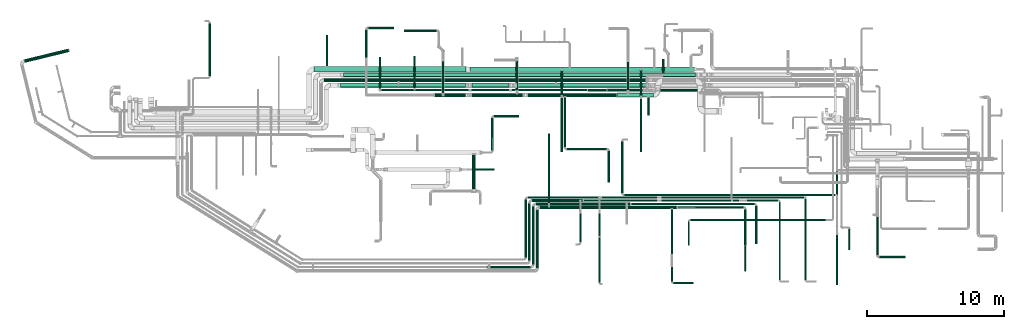
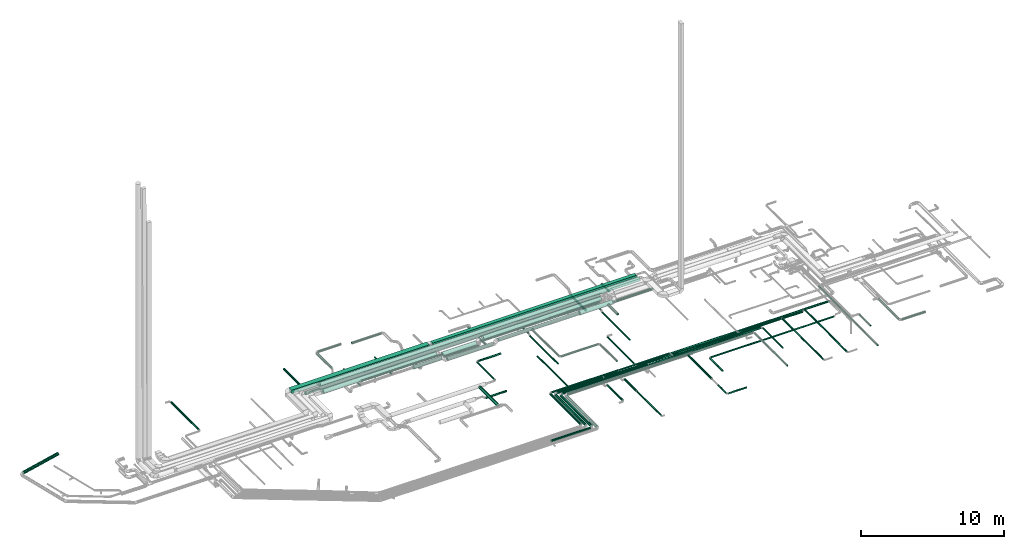
# One storey, part 31 of 92: 77 flow segments.
"""IFC2X3 building model written with IfcOpenShell, lengths in millimetres."""

import ifcopenshell
import ifcopenshell.guid

model = None  # the IFC model being written
_history = None  # IfcOwnerHistory: only IFC2X3 demands one
_inside = {}  # id of a spatial element -> (the spatial element, [elements in it])
_under = {}  # id of a project, library or spatial element -> (it, [spatial elements below it])
_declared = {}  # id of a project -> (the project, [libraries it declares])
_typed = {}  # id of a type object -> (the type object, [elements of that type])
_made_of = {}  # id of a material, layer set ... -> (it, [elements and type objects made of it])


def new_model(schema):
    """Start an empty IFC model of exactly this schema.

    Asked for "IFC4X3", IfcOpenShell would pick the latest addendum, in which some entities
    have other attributes; the version numbers below select the first issue.
    IFC2X3 requires an IfcOwnerHistory on every rooted entity: one is made here for all.
    """
    global model, _history
    if schema == "IFC4X3":
        model = ifcopenshell.file(schema_version=(4, 3, 0, 0))
    else:
        model = ifcopenshell.file(schema=schema)
    _inside.clear()
    _under.clear()
    _declared.clear()
    _typed.clear()
    _made_of.clear()
    _history = None
    if model.schema == "IFC2X3":
        org = make("IfcOrganization", Name="unknown")
        user = make(
            "IfcPersonAndOrganization",
            ThePerson=make("IfcPerson", FamilyName="unknown"),
            TheOrganization=org,
        )
        app = make(
            "IfcApplication",
            ApplicationDeveloper=org,
            Version="unknown",
            ApplicationFullName="unknown",
            ApplicationIdentifier="unknown",
        )
        _history = make(
            "IfcOwnerHistory",
            OwningUser=user,
            OwningApplication=app,
            ChangeAction="ADDED",
            CreationDate=0,
        )
    return model


def make(cls, **values):
    """One entity of the class cls with the attributes given. An attribute that is None is left unset."""
    return model.create_entity(
        cls, **{name: value for name, value in values.items() if value is not None}
    )


def entity(cls, *values):
    """Any entity or typed value of the class cls, its attributes in the order of the schema. None: left unset."""
    e = model.create_entity(cls)
    for i, value in enumerate(values):
        if value is not None:
            e[i] = value
    return e


def rooted(cls, **values):
    """An entity with a GlobalId (a new one), such as an element, a storey or a relation."""
    return make(cls, GlobalId=ifcopenshell.guid.new(), OwnerHistory=_history, **values)


def si_unit(unit_type, name, prefix=None):
    """IfcSIUnit, for example si_unit("LENGTHUNIT", "METRE", prefix="MILLI")."""
    return make("IfcSIUnit", UnitType=unit_type, Prefix=prefix, Name=name)


def converted_unit(unit_type, name, factor, base, dimensions=None, offset=None):
    """IfcConversionBasedUnit, such as the inch: factor (a typed value) times the base unit."""
    return make(
        "IfcConversionBasedUnit"
        if offset is None
        else "IfcConversionBasedUnitWithOffset",
        ConversionOffset=offset,
        Dimensions=None
        if dimensions is None
        else entity("IfcDimensionalExponents", *dimensions),
        UnitType=unit_type,
        Name=name,
        ConversionFactor=make(
            "IfcMeasureWithUnit", ValueComponent=factor, UnitComponent=base
        ),
    )


def derived_unit(unit_type, elements):
    """IfcDerivedUnit: a product of units, each with its exponent."""
    return make(
        "IfcDerivedUnit",
        Elements=[
            make("IfcDerivedUnitElement", Unit=unit, Exponent=power)
            for unit, power in elements
        ],
        UnitType=unit_type,
    )


def assignment(units):
    """IfcUnitAssignment: the units of a project."""
    return None if units is None else make("IfcUnitAssignment", Units=units)


def point(xyz):
    """IfcCartesianPoint."""
    return None if xyz is None else make("IfcCartesianPoint", Coordinates=xyz)


def direction(xyz):
    """IfcDirection."""
    return None if xyz is None else make("IfcDirection", DirectionRatios=xyz)


def frame(location, z_axis=None, x_axis=None):
    """IfcAxis2Placement3D, a coordinate frame: its origin and axes. An axis left out is left unset."""
    return make(
        "IfcAxis2Placement3D",
        Location=point(location),
        Axis=direction(z_axis),
        RefDirection=direction(x_axis),
    )


def frame_2d(location, x_axis=None):
    """IfcAxis2Placement2D, a coordinate frame in the plane: its origin and x axis."""
    return make(
        "IfcAxis2Placement2D", Location=point(location), RefDirection=direction(x_axis)
    )


def origin():
    """The frame at (0, 0, 0) with its axes left unset."""
    return frame((0.0, 0.0, 0.0))


def origin_2d_with_axis():
    """The frame at (0, 0) in the plane with the x axis (1, 0) written out."""
    return frame_2d((0.0, 0.0), x_axis=(1.0, 0.0))


def place(relative_to, where):
    """IfcLocalPlacement: puts the frame where relative to a parent placement (None: the world)."""
    return make(
        "IfcLocalPlacement", PlacementRelTo=relative_to, RelativePlacement=where
    )


def context(
    kind, dimensions, precision=None, world=None, true_north=None, identifier=None
):
    """IfcGeometricRepresentationContext, for example the 3D "Model" context."""
    return make(
        "IfcGeometricRepresentationContext",
        ContextIdentifier=identifier,
        ContextType=kind,
        CoordinateSpaceDimension=dimensions,
        Precision=precision,
        WorldCoordinateSystem=world,
        TrueNorth=true_north,
    )


def subcontext(parent, identifier, kind, view, scale=None):
    """IfcGeometricRepresentationSubContext, for example "Body" below "Model"."""
    return make(
        "IfcGeometricRepresentationSubContext",
        ContextIdentifier=identifier,
        ContextType=kind,
        ParentContext=parent,
        TargetScale=scale,
        TargetView=view,
    )


def project(units=None, contexts=None):
    """IfcProject with its units and contexts."""
    return rooted(
        "IfcProject",
        Name="project",
        RepresentationContexts=contexts,
        UnitsInContext=assignment(units),
    )


def spatial(cls, under=None, at=None, **own):
    """A site, building, storey or space (cls), placed at a placement, below another one or the project."""
    s = rooted(cls, ObjectPlacement=at, **own)
    if under is not None:
        _under.setdefault(under.id(), (under, []))[1].append(s)
    return s


def profile(cls, at=None, kind="AREA", **sizes):
    """A parametric profile (cls). Its sizes go by their IFC names, for example OverallWidth=200.0."""
    return make(cls, ProfileType=kind, Position=at, **sizes)


def rectangle(**sizes):
    """IfcRectangleProfileDef."""
    return profile("IfcRectangleProfileDef", **sizes)


def circle(**sizes):
    """IfcCircleProfileDef."""
    return profile("IfcCircleProfileDef", **sizes)


def extrude(swept, where, along, depth):
    """IfcExtrudedAreaSolid: the profile swept, set in the frame where, extruded along a direction by depth."""
    return make(
        "IfcExtrudedAreaSolid",
        SweptArea=swept,
        Position=where,
        ExtrudedDirection=direction(along),
        Depth=depth,
    )


def shape(context_of_items, identifier, shape_type, items):
    """IfcShapeRepresentation: the items that make up one representation, for example the "Body"."""
    return make(
        "IfcShapeRepresentation",
        ContextOfItems=context_of_items,
        RepresentationIdentifier=identifier,
        RepresentationType=shape_type,
        Items=items,
    )


def made_of(thing, what):
    """Note that an element or type object is made of a material, layer set ...; save() writes the relation."""
    if what is not None:
        _made_of.setdefault(what.id(), (what, []))[1].append(thing)
    return thing


def type_object(cls, material=None, **own):
    """A type object (cls), such as IfcWallType, which elements share."""
    return made_of(rooted(cls, **own), material)


def element(
    cls,
    number,
    at=None,
    inside=None,
    cuts=None,
    type_object=None,
    material=None,
    context=None,
    identifier="Body",
    shape_type=None,
    held_by="IfcProductDefinitionShape",
    body=None,
    shapes=None,
    **own,
):
    """One element of the class cls, such as IfcWall. Its Tag is "e" and its number.

    at: its placement. inside: the storey or other place that contains it. cuts: it is an
    opening in that element (IfcRelVoidsElement). A single representation is given by context,
    identifier, shape_type and body (its items); several are given by shapes. held_by: the class
    of the entity that holds the representations. save() writes the other relations.
    """
    e = rooted(cls, Tag="e%d" % number, ObjectPlacement=at, **own)
    if body is not None:
        shapes = [shape(context, identifier, shape_type, body)]
    if shapes is not None:
        e.Representation = make(held_by, Representations=shapes)
    if inside is not None:
        _inside.setdefault(inside.id(), (inside, []))[1].append(e)
    if cuts is not None:
        rooted(
            "IfcRelVoidsElement", RelatingBuildingElement=cuts, RelatedOpeningElement=e
        )
    if type_object is not None:
        _typed.setdefault(type_object.id(), (type_object, []))[1].append(e)
    return made_of(e, material)


def aggregate(whole, parts):
    """IfcRelAggregates: a whole, such as a stair, and the parts it consists of."""
    return rooted("IfcRelAggregates", RelatingObject=whole, RelatedObjects=parts)


def save(model, path):
    """Write the relations noted so far, then the file.

    IfcRelAggregates (storeys below a building ...), IfcRelContainedInSpatialStructure (elements
    in a storey), IfcRelDefinesByType, IfcRelAssociatesMaterial and IfcRelDeclares: one each for
    every whole, place, type object, material and project.
    """
    for whole, parts in _under.values():
        aggregate(whole, parts)
    for where, things in _inside.values():
        rooted(
            "IfcRelContainedInSpatialStructure",
            RelatedElements=things,
            RelatingStructure=where,
        )
    for kind, things in _typed.values():
        rooted("IfcRelDefinesByType", RelatedObjects=things, RelatingType=kind)
    for what, things in _made_of.values():
        rooted("IfcRelAssociatesMaterial", RelatedObjects=things, RelatingMaterial=what)
    for by, libraries in _declared.values():
        rooted("IfcRelDeclares", RelatingContext=by, RelatedDefinitions=libraries)
    model.write(path)


model = new_model("IFC2X3")

# Units and contexts
model_context = context("Model", 3, precision=0.01, world=origin(), true_north=direction((6.12303176911189e-17, 1.0)))
body_context = subcontext(model_context, "Body", "Model", "MODEL_VIEW")
ifc_project = project(units=[si_unit("LENGTHUNIT", "METRE", prefix="MILLI"), si_unit("AREAUNIT", "SQUARE_METRE"), si_unit("VOLUMEUNIT", "CUBIC_METRE"), converted_unit("PLANEANGLEUNIT", "DEGREE", entity("IfcRatioMeasure", 0.0174532925199433), si_unit("PLANEANGLEUNIT", "RADIAN"), dimensions=[0, 0, 0, 0, 0, 0, 0]), si_unit("MASSUNIT", "GRAM", prefix="KILO"), derived_unit("MASSDENSITYUNIT", [(si_unit("MASSUNIT", "GRAM", prefix="KILO"), 1), (si_unit("LENGTHUNIT", "METRE"), -3)]), derived_unit("MOMENTOFINERTIAUNIT", [(si_unit("LENGTHUNIT", "METRE"), 4)]), si_unit("TIMEUNIT", "SECOND"), si_unit("FREQUENCYUNIT", "HERTZ"), si_unit("THERMODYNAMICTEMPERATUREUNIT", "DEGREE_CELSIUS"), derived_unit("THERMALTRANSMITTANCEUNIT", [(si_unit("MASSUNIT", "GRAM", prefix="KILO"), 1), (si_unit("THERMODYNAMICTEMPERATUREUNIT", "KELVIN"), -1), (si_unit("TIMEUNIT", "SECOND"), -3)]), derived_unit("VOLUMETRICFLOWRATEUNIT", [(si_unit("LENGTHUNIT", "METRE"), 3), (si_unit("TIMEUNIT", "SECOND"), -1)]), derived_unit("MASSFLOWRATEUNIT", [(si_unit("MASSUNIT", "GRAM", prefix="KILO"), 1), (si_unit("TIMEUNIT", "SECOND"), -1)]), derived_unit("ROTATIONALFREQUENCYUNIT", [(si_unit("TIMEUNIT", "SECOND"), -1)]), si_unit("ELECTRICCURRENTUNIT", "AMPERE"), si_unit("ELECTRICVOLTAGEUNIT", "VOLT"), si_unit("POWERUNIT", "WATT"), si_unit("FORCEUNIT", "NEWTON", prefix="KILO"), si_unit("ILLUMINANCEUNIT", "LUX"), si_unit("LUMINOUSFLUXUNIT", "LUMEN"), si_unit("LUMINOUSINTENSITYUNIT", "CANDELA"), derived_unit("USERDEFINED", [(si_unit("MASSUNIT", "GRAM", prefix="KILO"), -1), (si_unit("LENGTHUNIT", "METRE"), -2), (si_unit("TIMEUNIT", "SECOND"), 3), (si_unit("LUMINOUSFLUXUNIT", "LUMEN"), 1)]), derived_unit("LINEARVELOCITYUNIT", [(si_unit("LENGTHUNIT", "METRE"), 1), (si_unit("TIMEUNIT", "SECOND"), -1)]), si_unit("PRESSUREUNIT", "PASCAL"), derived_unit("USERDEFINED", [(si_unit("LENGTHUNIT", "METRE"), -2), (si_unit("MASSUNIT", "GRAM", prefix="KILO"), 1), (si_unit("TIMEUNIT", "SECOND"), -2)]), derived_unit("LINEARFORCEUNIT", [(si_unit("MASSUNIT", "GRAM", prefix="KILO"), 1), (si_unit("LENGTHUNIT", "METRE"), 1), (si_unit("TIMEUNIT", "SECOND"), -2), (si_unit("LENGTHUNIT", "METRE"), -1)]), derived_unit("PLANARFORCEUNIT", [(si_unit("MASSUNIT", "GRAM", prefix="KILO"), 1), (si_unit("LENGTHUNIT", "METRE"), 1), (si_unit("TIMEUNIT", "SECOND"), -2), (si_unit("LENGTHUNIT", "METRE"), -2)])], contexts=[model_context])

# Site, building, storey
site_placement = place(None, origin())
site = spatial("IfcSite", under=ifc_project, at=site_placement, CompositionType="ELEMENT")
building_placement = place(site_placement, origin())
building = spatial("IfcBuilding", under=site, at=building_placement, CompositionType="ELEMENT")
storey_placement = place(building_placement, frame((0.0, 0.0, 4200.0)))
storey = spatial("IfcBuildingStorey", under=building, at=storey_placement, CompositionType="ELEMENT", Elevation=4200.0)

# Flow segments
duct_segment_type_1 = type_object("IfcDuctSegmentType", PredefinedType="NOTDEFINED")
flow_segment_1_placement = place(storey_placement, frame((33469.63, 15979.51, 3150.0)))
element("IfcFlowSegment", 1, at=flow_segment_1_placement, inside=storey, type_object=duct_segment_type_1, context=body_context, shape_type="SweptSolid", body=[
    extrude(rectangle(XDim=16415.04873584, YDim=300.000000000001, at=origin_2d_with_axis()), frame((8208.23, 150.0, 20.0), z_axis=(-0.00243678837898795, 0.0, 0.999997031026791), x_axis=(-0.999997031026791, 0.0, -0.00243678837898795)), (0.0, 0.0, 1.0), 299.999999999999),
])
flow_segment_2_placement = place(storey_placement, frame((22075.0, 15924.51, 3150.0)))
element("IfcFlowSegment", 2, at=flow_segment_2_placement, inside=storey, type_object=duct_segment_type_1, context=body_context, shape_type="SweptSolid", body=[
    extrude(rectangle(XDim=11095.0, YDim=400.0, at=origin_2d_with_axis()), frame((5547.5, 200.0, 0.0), z_axis=(0.0, 0.0, 1.0), x_axis=(-1.0, 0.0, 0.0)), (0.0, 0.0, 1.0), 299.999999999999),
])
duct_segment_type_2 = type_object("IfcDuctSegmentType", PredefinedType="NOTDEFINED")
flow_segment_3_placement = place(storey_placement, frame((63189.76, 2558.91, 3138.4)))
element("IfcFlowSegment", 3, at=flow_segment_3_placement, inside=storey, type_object=duct_segment_type_2, context=body_context, shape_type="SweptSolid", body=[
    extrude(circle(Radius=80.0, at=origin_2d_with_axis()), frame((81.6, 0.0, 81.6), z_axis=(0.0, 1.0, 0.0), x_axis=(1.0, 0.0, 0.0)), (0.0, 0.0, 1.0), 2782.5164097574),
])
flow_segment_4_placement = place(storey_placement, frame((63431.35, 2317.31, 3138.4)))
element("IfcFlowSegment", 4, at=flow_segment_4_placement, inside=storey, type_object=duct_segment_type_2, context=body_context, shape_type="SweptSolid", body=[
    extrude(circle(Radius=80.0, at=origin_2d_with_axis()), frame((0.0, 81.6, 81.6), z_axis=(1.0, 0.0, 0.0), x_axis=(0.0, -1.0, 0.0)), (0.0, 0.0, 1.0), 1889.99999999994),
])
flow_segment_5_placement = place(storey_placement, frame((22935.02, 16344.51, 3218.4)))
element("IfcFlowSegment", 5, at=flow_segment_5_placement, inside=storey, type_object=duct_segment_type_2, context=body_context, shape_type="SweptSolid", body=[
    extrude(circle(Radius=80.0, at=origin_2d_with_axis()), frame((81.6, 0.0, 81.6), z_axis=(0.0, 1.0, 0.0), x_axis=(1.0, 0.0, 0.0)), (0.0, 0.0, 1.0), 2289.99999999988),
])
flow_segment_6_placement = place(storey_placement, frame((14362.46, 15639.71, 2858.4)))
element("IfcFlowSegment", 6, at=flow_segment_6_placement, inside=storey, type_object=duct_segment_type_2, context=body_context, shape_type="SweptSolid", body=[
    extrude(circle(Radius=80.0, at=origin_2d_with_axis()), frame((81.6, 0.0, 81.6), z_axis=(0.0, 1.0, 0.0), x_axis=(1.0, 0.0, 0.0)), (0.0, 0.0, 1.0), 3850.94839972515),
])
flow_segment_7_placement = place(storey_placement, frame((34723.33, 1558.33, 3248.4)))
element("IfcFlowSegment", 7, at=flow_segment_7_placement, inside=storey, type_object=duct_segment_type_2, context=body_context, shape_type="SweptSolid", body=[
    extrude(circle(Radius=100.0, at=origin_2d_with_axis()), frame((0.0, 101.6, 101.6), z_axis=(1.0, 0.0, 0.0), x_axis=(0.0, 1.0, 0.0)), (0.0, 0.0, 1.0), 3176.33865966035),
])
flow_segment_8_placement = place(storey_placement, frame((37998.07, 1859.92, 3248.4)))
element("IfcFlowSegment", 8, at=flow_segment_8_placement, inside=storey, type_object=duct_segment_type_2, context=body_context, shape_type="SweptSolid", body=[
    extrude(circle(Radius=100.0, at=origin_2d_with_axis()), frame((101.6, 0.0, 101.6), z_axis=(0.0, 1.0, 0.0), x_axis=(1.0, 0.0, 0.0)), (0.0, 0.0, 1.0), 4214.89014323062),
])
flow_segment_9_placement = place(storey_placement, frame((38299.67, 6173.22, 3248.4)))
element("IfcFlowSegment", 9, at=flow_segment_9_placement, inside=storey, type_object=duct_segment_type_2, context=body_context, shape_type="SweptSolid", body=[
    extrude(circle(Radius=100.0, at=origin_2d_with_axis()), frame((0.0, 101.6, 101.6), z_axis=(1.0, 0.0, 0.0), x_axis=(0.0, -1.0, 0.0)), (0.0, 0.0, 1.0), 6900.00000000001),
])
flow_segment_10_placement = place(storey_placement, frame((45274.67, 6210.72, 3285.9)))
element("IfcFlowSegment", 10, at=flow_segment_10_placement, inside=storey, type_object=duct_segment_type_2, context=body_context, shape_type="SweptSolid", body=[
    extrude(circle(Radius=62.5, at=origin_2d_with_axis()), frame((0.0, 64.1, 64.1), z_axis=(1.0, 0.0, 0.0), x_axis=(0.0, 1.0, 0.0)), (0.0, 0.0, 1.0), 9009.65781),
])
flow_segment_11_placement = place(storey_placement, frame((54345.23, 3386.61, 3285.9)))
element("IfcFlowSegment", 11, at=flow_segment_11_placement, inside=storey, type_object=duct_segment_type_2, context=body_context, shape_type="SweptSolid", body=[
    extrude(circle(Radius=62.5, at=origin_2d_with_axis()), frame((64.1, 0.0, 64.1), z_axis=(0.0, 1.0, 0.0), x_axis=(-1.0, 0.0, 0.0)), (0.0, 0.0, 1.0), 2763.20000000015),
])
flow_segment_12_placement = place(storey_placement, frame((38288.15, 1579.97, 3248.4)))
element("IfcFlowSegment", 12, at=flow_segment_12_placement, inside=storey, type_object=duct_segment_type_2, context=body_context, shape_type="SweptSolid", body=[
    extrude(circle(Radius=100.0, at=origin_2d_with_axis()), frame((101.6, 0.0, 101.6), z_axis=(0.0, 1.0, 0.0), x_axis=(1.0, 0.0, 0.0)), (0.0, 0.0, 1.0), 4244.85231843357),
])
flow_segment_13_placement = place(storey_placement, frame((38589.74, 5922.98, 3248.4)))
element("IfcFlowSegment", 13, at=flow_segment_13_placement, inside=storey, type_object=duct_segment_type_2, context=body_context, shape_type="SweptSolid", body=[
    extrude(circle(Radius=100.0, at=origin_2d_with_axis()), frame((0.0, 101.6, 101.6), z_axis=(1.0, 0.0, 0.0), x_axis=(0.0, -1.0, 0.0)), (0.0, 0.0, 1.0), 10000.0),
])
flow_segment_14_placement = place(storey_placement, frame((39191.59, 6325.4, 3035.9)))
element("IfcFlowSegment", 14, at=flow_segment_14_placement, inside=storey, type_object=duct_segment_type_2, context=body_context, shape_type="SweptSolid", body=[
    extrude(circle(Radius=62.5, at=origin_2d_with_axis()), frame((64.1, 0.0, 64.1), z_axis=(0.0, 1.0, 0.0), x_axis=(1.0, 0.0, 0.0)), (0.0, 0.0, 1.0), 5076.10296697174),
])
flow_segment_15_placement = place(storey_placement, frame((48664.74, 5960.48, 3285.9)))
element("IfcFlowSegment", 15, at=flow_segment_15_placement, inside=storey, type_object=duct_segment_type_2, context=body_context, shape_type="SweptSolid", body=[
    extrude(circle(Radius=62.5, at=origin_2d_with_axis()), frame((0.0, 64.1, 64.1), z_axis=(1.0, 0.0, 0.0), x_axis=(0.0, 1.0, 0.0)), (0.0, 0.0, 1.0), 4816.79215817312),
])
flow_segment_16_placement = place(storey_placement, frame((53542.44, 3240.11, 3285.9)))
element("IfcFlowSegment", 16, at=flow_segment_16_placement, inside=storey, type_object=duct_segment_type_2, context=body_context, shape_type="SweptSolid", body=[
    extrude(circle(Radius=62.5, at=origin_2d_with_axis()), frame((64.1, 0.0, 64.1), z_axis=(0.0, 1.0, 0.0), x_axis=(-1.0, 0.0, 0.0)), (0.0, 0.0, 1.0), 2659.465339106),
])
flow_segment_17_placement = place(storey_placement, frame((53554.91, 1369.83, 3298.4)))
element("IfcFlowSegment", 17, at=flow_segment_17_placement, inside=storey, type_object=duct_segment_type_2, context=body_context, shape_type="SweptSolid", body=[
    extrude(circle(Radius=50.0, at=origin_2d_with_axis()), frame((51.6, 0.0, 51.6), z_axis=(1.46979839557757e-05, 1.0, 0.0), x_axis=(-1.0, 1.46979839557757e-05, 0.0)), (0.0, 0.0, 1.0), 1845.2883705389),
])
flow_segment_18_placement = place(storey_placement, frame((48158.4, 2604.83, 3268.4)))
element("IfcFlowSegment", 18, at=flow_segment_18_placement, inside=storey, type_object=duct_segment_type_2, context=body_context, shape_type="SweptSolid", body=[
    extrude(circle(Radius=80.0, at=origin_2d_with_axis()), frame((81.6, 0.0, 81.6), z_axis=(0.0, 1.0, 0.0), x_axis=(1.0, 0.0, 0.0)), (0.0, 0.0, 1.0), 3299.75370936451),
])
flow_segment_19_placement = place(storey_placement, frame((48188.4, 595.45, 3298.4)))
element("IfcFlowSegment", 19, at=flow_segment_19_placement, inside=storey, type_object=duct_segment_type_2, context=body_context, shape_type="SweptSolid", body=[
    extrude(circle(Radius=50.0, at=origin_2d_with_axis()), frame((51.6, 0.0, 51.6), z_axis=(0.0, 1.0, 0.0), x_axis=(-1.0, 0.0, 0.0)), (0.0, 0.0, 1.0), 1104.37492000003),
])
flow_segment_20_placement = place(storey_placement, frame((48340.0, 443.86, 3298.4)))
element("IfcFlowSegment", 20, at=flow_segment_20_placement, inside=storey, type_object=duct_segment_type_2, context=body_context, shape_type="SweptSolid", body=[
    extrude(circle(Radius=50.0, at=origin_2d_with_axis()), frame((0.0, 51.6, 51.6), z_axis=(1.0, 0.0, 0.0), x_axis=(0.0, -1.0, 0.0)), (0.0, 0.0, 1.0), 1480.00000000001),
])
flow_segment_21_placement = place(storey_placement, frame((37473.28, 2380.0, 3278.4)))
element("IfcFlowSegment", 21, at=flow_segment_21_placement, inside=storey, type_object=duct_segment_type_2, context=body_context, shape_type="SweptSolid", body=[
    extrude(circle(Radius=80.0, at=origin_2d_with_axis()), frame((81.6, 0.0, 81.6), z_axis=(0.0, 1.0, 0.0), x_axis=(1.0, 0.0, 0.0)), (0.0, 0.0, 1.0), 4215.03973085738),
])
flow_segment_22_placement = place(storey_placement, frame((37714.87, 6673.44, 3278.4)))
element("IfcFlowSegment", 22, at=flow_segment_22_placement, inside=storey, type_object=duct_segment_type_2, context=body_context, shape_type="SweptSolid", body=[
    extrude(circle(Radius=80.0, at=origin_2d_with_axis()), frame((0.0, 81.6, 81.6), z_axis=(1.0, 0.0, 0.0), x_axis=(0.0, 1.0, 0.0)), (0.0, 0.0, 1.0), 5352.89450896011),
])
flow_segment_23_placement = place(storey_placement, frame((42902.64, 523.14, 3298.4)))
element("IfcFlowSegment", 23, at=flow_segment_23_placement, inside=storey, type_object=duct_segment_type_2, context=body_context, shape_type="SweptSolid", body=[
    extrude(circle(Radius=50.0, at=origin_2d_with_axis()), frame((51.6, 0.0, 51.6), z_axis=(0.0, 1.0, 0.0), x_axis=(-1.0, 0.0, 0.0)), (0.0, 0.0, 1.0), 3326.89716131193),
])
flow_segment_24_placement = place(storey_placement, frame((43127.77, 6703.44, 3308.4)))
element("IfcFlowSegment", 24, at=flow_segment_24_placement, inside=storey, type_object=duct_segment_type_2, context=body_context, shape_type="SweptSolid", body=[
    extrude(circle(Radius=50.0, at=origin_2d_with_axis()), frame((0.0, 51.6, 51.6), z_axis=(1.0, 0.0, 0.0), x_axis=(0.0, -1.0, 0.0)), (0.0, 0.0, 1.0), 4060.95188480217),
])
flow_segment_25_placement = place(storey_placement, frame((36908.04, 14797.9, 3140.9)))
element("IfcFlowSegment", 25, at=flow_segment_25_placement, inside=storey, type_object=duct_segment_type_2, context=body_context, shape_type="SweptSolid", body=[
    extrude(circle(Radius=157.5, at=origin_2d_with_axis()), frame((0.0, 159.1, 159.1), z_axis=(1.0, 0.0, 0.0), x_axis=(0.0, 1.0, 0.0)), (0.0, 0.0, 1.0), 9507.22972697121),
])
flow_segment_26_placement = place(storey_placement, frame((871.65, 16601.37, 3233.4)))
element("IfcFlowSegment", 26, at=flow_segment_26_placement, inside=storey, type_object=duct_segment_type_2, context=body_context, shape_type="SweptSolid", body=[
    extrude(circle(Radius=125.0, at=origin_2d_with_axis()), frame((31.2, 123.04, 126.6), z_axis=(0.971552058141474, 0.236826092990333, 0.0), x_axis=(0.236826092990333, -0.971552058141474, 0.0)), (0.0, 0.0, 1.0), 3341.53518929974),
])
flow_segment_27_placement = place(storey_placement, frame((37717.54, 2139.96, 3258.4)))
element("IfcFlowSegment", 27, at=flow_segment_27_placement, inside=storey, type_object=duct_segment_type_2, context=body_context, shape_type="SweptSolid", body=[
    extrude(circle(Radius=100.0, at=origin_2d_with_axis()), frame((101.6, 0.0, 101.6), z_axis=(0.0, 1.0, 0.0), x_axis=(1.0, 0.0, 0.0)), (0.0, 0.0, 1.0), 4184.88732607687),
])
flow_segment_28_placement = place(storey_placement, frame((61159.38, 2924.89, 3098.4)))
element("IfcFlowSegment", 28, at=flow_segment_28_placement, inside=storey, type_object=duct_segment_type_2, context=body_context, shape_type="SweptSolid", body=[
    extrude(circle(Radius=50.0, at=origin_2d_with_axis()), frame((51.6, 0.0, 51.6), z_axis=(0.0, 1.0, 0.0), x_axis=(-1.0, 0.0, 0.0)), (0.0, 0.0, 1.0), 1530.59800714042),
])
flow_segment_29_placement = place(storey_placement, frame((57973.96, 702.32, 3348.4)))
element("IfcFlowSegment", 29, at=flow_segment_29_placement, inside=storey, type_object=duct_segment_type_2, context=body_context, shape_type="SweptSolid", body=[
    extrude(circle(Radius=50.0, at=origin_2d_with_axis()), frame((51.6, 0.0, 51.6), z_axis=(0.0, 1.0, 0.0), x_axis=(-1.0, 0.0, 0.0)), (0.0, 0.0, 1.0), 5952.7187231084),
])
flow_segment_30_placement = place(storey_placement, frame((41469.24, 3479.77, 3263.64)))
element("IfcFlowSegment", 30, at=flow_segment_30_placement, inside=storey, type_object=duct_segment_type_2, context=body_context, shape_type="SweptSolid", body=[
    extrude(circle(Radius=80.0, at=origin_2d_with_axis()), frame((81.6, 0.0, 81.6), z_axis=(0.0, 1.0, 0.0), x_axis=(1.0, 0.0, 0.0)), (0.0, 0.0, 1.0), 2090.73393103333),
])
flow_segment_31_placement = place(storey_placement, frame((52700.11, 6470.75, 3348.4)))
element("IfcFlowSegment", 31, at=flow_segment_31_placement, inside=storey, type_object=duct_segment_type_2, context=body_context, shape_type="SweptSolid", body=[
    extrude(circle(Radius=50.0, at=origin_2d_with_axis()), frame((0.0, 51.6, 51.6), z_axis=(1.0, 0.0, 0.0), x_axis=(0.0, 1.0, 0.0)), (0.0, 0.0, 1.0), 3333.45568879652),
])
flow_segment_32_placement = place(storey_placement, frame((38019.13, 6423.25, 3258.4)))
element("IfcFlowSegment", 32, at=flow_segment_32_placement, inside=storey, type_object=duct_segment_type_2, context=body_context, shape_type="SweptSolid", body=[
    extrude(circle(Radius=100.0, at=origin_2d_with_axis()), frame((0.0, 101.6, 101.6), z_axis=(1.0, 0.0, 0.0), x_axis=(0.0, -1.0, 0.0)), (0.0, 0.0, 1.0), 3694.23043778437),
])
flow_segment_33_placement = place(storey_placement, frame((44554.67, 7068.28, 3095.9)))
element("IfcFlowSegment", 33, at=flow_segment_33_placement, inside=storey, type_object=duct_segment_type_2, context=body_context, shape_type="SweptSolid", body=[
    extrude(circle(Radius=62.5, at=origin_2d_with_axis()), frame((64.1, 0.0, 64.1), z_axis=(0.0, 1.0, 0.0), x_axis=(1.0, 0.0, 0.0)), (0.0, 0.0, 1.0), 3796.71503982172),
])
flow_segment_34_placement = place(storey_placement, frame((44743.77, 6879.19, 3095.9)))
element("IfcFlowSegment", 34, at=flow_segment_34_placement, inside=storey, type_object=duct_segment_type_2, context=body_context, shape_type="SweptSolid", body=[
    extrude(circle(Radius=62.5, at=origin_2d_with_axis()), frame((0.0, 64.1, 64.1), z_axis=(1.0, 0.0, 0.0), x_axis=(0.0, -1.0, 0.0)), (0.0, 0.0, 1.0), 15453.941984164),
])
flow_segment_35_placement = place(storey_placement, frame((56081.97, 700.4, 3348.4)))
element("IfcFlowSegment", 35, at=flow_segment_35_placement, inside=storey, type_object=duct_segment_type_2, context=body_context, shape_type="SweptSolid", body=[
    extrude(circle(Radius=50.0, at=origin_2d_with_axis()), frame((51.6, 0.0, 51.6), z_axis=(0.0, 1.0, 0.0), x_axis=(-1.0, 0.0, 0.0)), (0.0, 0.0, 1.0), 5721.94436317677),
])
flow_segment_36_placement = place(storey_placement, frame((47528.4, 15821.98, 2918.4)))
element("IfcFlowSegment", 36, at=flow_segment_36_placement, inside=storey, type_object=duct_segment_type_2, context=body_context, shape_type="SweptSolid", body=[
    extrude(circle(Radius=80.0, at=origin_2d_with_axis()), frame((81.6, 0.0, 81.6), z_axis=(0.0, 1.0, 0.0), x_axis=(1.0, 0.0, 0.0)), (0.0, 0.0, 1.0), 1069.53796275342),
])
flow_segment_37_placement = place(storey_placement, frame((37727.45, 14115.4, 3173.4)))
element("IfcFlowSegment", 37, at=flow_segment_37_placement, inside=storey, type_object=duct_segment_type_2, context=body_context, shape_type="SweptSolid", body=[
    extrude(circle(Radius=125.0, at=origin_2d_with_axis()), frame((0.0, 126.6, 126.6), z_axis=(1.0, 0.0, 0.0), x_axis=(0.0, 1.0, 0.0)), (0.0, 0.0, 1.0), 6470.60249485662),
])
flow_segment_38_placement = place(storey_placement, frame((40354.43, 10417.36, 3235.9)))
element("IfcFlowSegment", 38, at=flow_segment_38_placement, inside=storey, type_object=duct_segment_type_2, context=body_context, shape_type="SweptSolid", body=[
    extrude(circle(Radius=62.5, at=origin_2d_with_axis()), frame((64.1, 0.0, 64.1), z_axis=(0.0, 1.0, 0.0), x_axis=(1.0, 0.0, 0.0)), (0.0, 0.0, 1.0), 3679.63829635603),
])
flow_segment_39_placement = place(storey_placement, frame((40543.53, 10228.27, 3235.9)))
element("IfcFlowSegment", 39, at=flow_segment_39_placement, inside=storey, type_object=duct_segment_type_2, context=body_context, shape_type="SweptSolid", body=[
    extrude(circle(Radius=62.5, at=origin_2d_with_axis()), frame((0.0, 64.1, 64.1), z_axis=(1.0, 0.0, 0.0), x_axis=(0.0, -1.0, 0.0)), (0.0, 0.0, 1.0), 2950.00000000008),
])
flow_segment_40_placement = place(storey_placement, frame((43554.43, 7853.98, 3235.9)))
element("IfcFlowSegment", 40, at=flow_segment_40_placement, inside=storey, type_object=duct_segment_type_2, context=body_context, shape_type="SweptSolid", body=[
    extrude(circle(Radius=62.5, at=origin_2d_with_axis()), frame((64.1, 0.0, 64.1), z_axis=(0.0, 1.0, 0.0), x_axis=(-1.0, 0.0, 0.0)), (0.0, 0.0, 1.0), 2313.38222094977),
])
flow_segment_41_placement = place(storey_placement, frame((31433.4, 14402.0, 2908.4)))
element("IfcFlowSegment", 41, at=flow_segment_41_placement, inside=storey, type_object=duct_segment_type_2, context=body_context, shape_type="SweptSolid", body=[
    extrude(circle(Radius=80.0, at=origin_2d_with_axis()), frame((81.6, 0.0, 81.6), z_axis=(0.0, 1.0, 0.0), x_axis=(-1.0, 0.0, 0.0)), (0.0, 0.0, 1.0), 2308.20336366427),
])
flow_segment_42_placement = place(storey_placement, frame((28660.55, 18866.88, 3258.4)))
element("IfcFlowSegment", 42, at=flow_segment_42_placement, inside=storey, type_object=duct_segment_type_2, context=body_context, shape_type="SweptSolid", body=[
    extrude(circle(Radius=80.0, at=origin_2d_with_axis()), frame((0.0, 81.6, 81.6), z_axis=(1.0, 0.0, 0.0), x_axis=(0.0, 1.0, 0.0)), (0.0, 0.0, 1.0), 2369.44948828407),
])
flow_segment_43_placement = place(storey_placement, frame((26051.62, 19063.38, 3318.4)))
element("IfcFlowSegment", 43, at=flow_segment_43_placement, inside=storey, type_object=duct_segment_type_2, context=body_context, shape_type="SweptSolid", body=[
    extrude(circle(Radius=80.0, at=origin_2d_with_axis()), frame((0.0, 81.6, 81.6), z_axis=(1.0, 0.0, 0.0), x_axis=(0.0, -1.0, 0.0)), (0.0, 0.0, 1.0), 1859.98447387882),
])
flow_segment_44_placement = place(storey_placement, frame((46442.59, 12754.72, 3218.4)))
element("IfcFlowSegment", 44, at=flow_segment_44_placement, inside=storey, type_object=duct_segment_type_2, context=body_context, shape_type="SweptSolid", body=[
    extrude(circle(Radius=80.0, at=origin_2d_with_axis()), frame((81.6, 0.0, 81.6), z_axis=(0.0, 1.0, 0.0), x_axis=(-1.0, 0.0, 0.0)), (0.0, 0.0, 1.0), 1309.78330185936),
])
flow_segment_45_placement = place(storey_placement, frame((43531.01, 14517.9, 3277.89)))
element("IfcFlowSegment", 45, at=flow_segment_45_placement, inside=storey, type_object=duct_segment_type_2, context=body_context, shape_type="SweptSolid", body=[
    extrude(circle(Radius=80.0, at=origin_2d_with_axis()), frame((0.0, 81.6, 81.6), z_axis=(1.0, 0.0, 0.0), x_axis=(0.0, 1.0, 0.0)), (0.0, 0.0, 1.0), 2569.99999999998),
])
flow_segment_46_placement = place(storey_placement, frame((42091.01, 14535.4, 3295.39)))
element("IfcFlowSegment", 46, at=flow_segment_46_placement, inside=storey, type_object=duct_segment_type_2, context=body_context, shape_type="SweptSolid", body=[
    extrude(circle(Radius=62.5, at=origin_2d_with_axis()), frame((0.0, 64.1, 64.1), z_axis=(1.0, 0.0, 0.0), x_axis=(0.0, 1.0, 0.0)), (0.0, 0.0, 1.0), 1405.0),
])
flow_segment_47_placement = place(storey_placement, frame((36545.15, 14547.9, 3307.89)))
element("IfcFlowSegment", 47, at=flow_segment_47_placement, inside=storey, type_object=duct_segment_type_2, context=body_context, shape_type="SweptSolid", body=[
    extrude(circle(Radius=50.0, at=origin_2d_with_axis()), frame((0.0, 51.6, 51.6), z_axis=(1.0, 0.0, 0.0), x_axis=(0.0, 1.0, 0.0)), (0.0, 0.0, 1.0), 5520.85892677341),
])
flow_segment_48_placement = place(storey_placement, frame((26834.47, 14699.5, 2898.4)))
element("IfcFlowSegment", 48, at=flow_segment_48_placement, inside=storey, type_object=duct_segment_type_2, context=body_context, shape_type="SweptSolid", body=[
    extrude(circle(Radius=50.0, at=origin_2d_with_axis()), frame((51.6, 0.0, 51.6), z_axis=(0.0, 1.0, 0.0), x_axis=(1.0, 0.0, 0.0)), (0.0, 0.0, 1.0), 2300.00000000001),
])
flow_segment_49_placement = place(storey_placement, frame((35040.47, 10162.96, 3235.9)))
element("IfcFlowSegment", 49, at=flow_segment_49_placement, inside=storey, type_object=duct_segment_type_2, context=body_context, shape_type="SweptSolid", body=[
    extrude(circle(Radius=62.5, at=origin_2d_with_axis()), frame((64.1, 0.0, 64.1), z_axis=(0.0, 1.0, 0.0), x_axis=(1.0, 0.0, 0.0)), (0.0, 0.0, 1.0), 2410.00000000002),
])
flow_segment_50_placement = place(storey_placement, frame((33632.73, 7364.28, 3173.4)))
element("IfcFlowSegment", 50, at=flow_segment_50_placement, inside=storey, type_object=duct_segment_type_2, context=body_context, shape_type="SweptSolid", body=[
    extrude(circle(Radius=125.0, at=origin_2d_with_axis()), frame((126.6, 0.0, 126.6), z_axis=(0.0, 1.0, 0.0), x_axis=(-1.0, 0.0, 0.0)), (0.0, 0.0, 1.0), 2496.17319265463),
])
flow_segment_51_placement = place(storey_placement, frame((33604.23, 8735.88, 3035.9)))
element("IfcFlowSegment", 51, at=flow_segment_51_placement, inside=storey, type_object=duct_segment_type_2, context=body_context, shape_type="SweptSolid", body=[
    extrude(circle(Radius=62.5, at=origin_2d_with_axis()), frame((0.0, 64.1, 64.1), z_axis=(1.0, 0.0, 0.0), x_axis=(0.0, -1.0, 0.0)), (0.0, 0.0, 1.0), 1663.22328074821),
])
flow_segment_52_placement = place(storey_placement, frame((42872.64, 3910.04, 3268.4)))
element("IfcFlowSegment", 52, at=flow_segment_52_placement, inside=storey, type_object=duct_segment_type_2, context=body_context, shape_type="SweptSolid", body=[
    extrude(circle(Radius=80.0, at=origin_2d_with_axis()), frame((81.6, 0.0, 81.6), z_axis=(0.0, 1.0, 0.0), x_axis=(1.0, 0.0, 0.0)), (0.0, 0.0, 1.0), 1658.00583002028),
])
flow_segment_53_placement = place(storey_placement, frame((47481.08, 6473.25, 3098.4)))
element("IfcFlowSegment", 53, at=flow_segment_53_placement, inside=storey, type_object=duct_segment_type_2, context=body_context, shape_type="SweptSolid", body=[
    extrude(circle(Radius=50.0, at=origin_2d_with_axis()), frame((0.0, 51.6, 51.6), z_axis=(1.0, 0.0, 0.0), x_axis=(0.0, 1.0, 0.0)), (0.0, 0.0, 1.0), 5704.76561542374),
])
flow_segment_54_placement = place(storey_placement, frame((47481.56, 6703.44, 3098.4)))
element("IfcFlowSegment", 54, at=flow_segment_54_placement, inside=storey, type_object=duct_segment_type_2, context=body_context, shape_type="SweptSolid", body=[
    extrude(circle(Radius=50.0, at=origin_2d_with_axis()), frame((0.0, 51.6, 51.6), z_axis=(1.0, 0.0, 0.0), x_axis=(0.0, 1.0, 0.0)), (0.0, 0.0, 1.0), 10443.9974737631),
])
flow_segment_55_placement = place(storey_placement, frame((41813.36, 6473.25, 3308.4)))
element("IfcFlowSegment", 55, at=flow_segment_55_placement, inside=storey, type_object=duct_segment_type_2, context=body_context, shape_type="SweptSolid", body=[
    extrude(circle(Radius=50.0, at=origin_2d_with_axis()), frame((0.0, 51.6, 51.6), z_axis=(1.0, 0.0, 0.0), x_axis=(0.0, -1.0, 0.0)), (0.0, 0.0, 1.0), 5375.12762906429),
])
flow_segment_56_placement = place(storey_placement, frame((47063.58, 14497.9, 2898.4)))
element("IfcFlowSegment", 56, at=flow_segment_56_placement, inside=storey, type_object=duct_segment_type_2, context=body_context, shape_type="SweptSolid", body=[
    extrude(circle(Radius=100.0, at=origin_2d_with_axis()), frame((0.0, 101.6, 101.6), z_axis=(1.0, 0.0, 0.0), x_axis=(0.0, 1.0, 0.0)), (0.0, 0.0, 1.0), 3352.50350688958),
])
flow_segment_57_placement = place(storey_placement, frame((22820.98, 15212.9, 3173.4)))
element("IfcFlowSegment", 57, at=flow_segment_57_placement, inside=storey, type_object=duct_segment_type_2, context=body_context, shape_type="SweptSolid", body=[
    extrude(circle(Radius=125.0, at=origin_2d_with_axis()), frame((0.0, 126.6, 126.6), z_axis=(1.0, 0.0, 0.0), x_axis=(0.0, -1.0, 0.0)), (0.0, 0.0, 1.0), 23724.09576907),
])
flow_segment_58_placement = place(storey_placement, frame((26986.06, 14547.9, 3298.4)))
element("IfcFlowSegment", 58, at=flow_segment_58_placement, inside=storey, type_object=duct_segment_type_2, context=body_context, shape_type="SweptSolid", body=[
    extrude(circle(Radius=50.0, at=origin_2d_with_axis()), frame((0.0, 51.6, 51.6), z_axis=(1.0, 0.0, 0.0), x_axis=(0.0, -1.0, 0.0)), (0.0, 0.0, 1.0), 6397.81081855833),
])
flow_segment_59_placement = place(storey_placement, frame((33583.87, 14547.9, 3038.4)))
element("IfcFlowSegment", 59, at=flow_segment_59_placement, inside=storey, type_object=duct_segment_type_2, context=body_context, shape_type="SweptSolid", body=[
    extrude(circle(Radius=50.0, at=origin_2d_with_axis()), frame((0.0, 51.6, 51.6), z_axis=(1.0, 0.0, 0.0), x_axis=(0.0, -1.0, 0.0)), (0.0, 0.0, 1.0), 2761.28136761189),
])
flow_segment_60_placement = place(storey_placement, frame((24019.73, 14797.9, 3088.4)))
element("IfcFlowSegment", 60, at=flow_segment_60_placement, inside=storey, type_object=duct_segment_type_2, context=body_context, shape_type="SweptSolid", body=[
    extrude(circle(Radius=157.5, at=origin_2d_with_axis()), frame((0.0, 159.1, 159.1), z_axis=(1.0, 0.0, 0.0), x_axis=(0.0, -1.0, 0.0)), (0.0, 0.0, 1.0), 9132.10965782929),
])
flow_segment_61_placement = place(storey_placement, frame((33628.08, 14797.9, 2910.9)))
element("IfcFlowSegment", 61, at=flow_segment_61_placement, inside=storey, type_object=duct_segment_type_2, context=body_context, shape_type="SweptSolid", body=[
    extrude(circle(Radius=157.5, at=origin_2d_with_axis()), frame((0.0, 159.1, 159.1), z_axis=(1.0, 0.0, 0.0), x_axis=(0.0, 1.0, 0.0)), (0.0, 0.0, 1.0), 2712.77397028846),
])
flow_segment_62_placement = place(storey_placement, frame((36821.88, 14581.05, 2938.4)))
element("IfcFlowSegment", 62, at=flow_segment_62_placement, inside=storey, type_object=duct_segment_type_2, context=body_context, shape_type="SweptSolid", body=[
    extrude(circle(Radius=80.0, at=origin_2d_with_axis()), frame((81.6, 0.0, 81.6), z_axis=(0.0, 1.0, 0.0), x_axis=(-1.0, 0.0, 0.0)), (0.0, 0.0, 1.0), 2362.80180988255),
])
flow_segment_63_placement = place(storey_placement, frame((33609.15, 14115.4, 2963.4)))
element("IfcFlowSegment", 63, at=flow_segment_63_placement, inside=storey, type_object=duct_segment_type_2, context=body_context, shape_type="SweptSolid", body=[
    extrude(circle(Radius=125.0, at=origin_2d_with_axis()), frame((0.0, 126.6, 126.6), z_axis=(1.0, 0.0, 0.0), x_axis=(0.0, 1.0, 0.0)), (0.0, 0.0, 1.0), 3701.1902490397),
])
flow_segment_64_placement = place(storey_placement, frame((30901.61, 14115.4, 3216.1)))
element("IfcFlowSegment", 64, at=flow_segment_64_placement, inside=storey, type_object=duct_segment_type_2, context=body_context, shape_type="SweptSolid", body=[
    extrude(circle(Radius=125.0, at=origin_2d_with_axis()), frame((0.0, 126.6, 126.6), z_axis=(1.0, 0.0, 0.0), x_axis=(0.0, -1.0, 0.0)), (0.0, 0.0, 1.0), 2247.74030313738),
])
flow_segment_65_placement = place(storey_placement, frame((29380.97, 14742.0, 2948.4)))
element("IfcFlowSegment", 65, at=flow_segment_65_placement, inside=storey, type_object=duct_segment_type_2, context=body_context, shape_type="SweptSolid", body=[
    extrude(circle(Radius=50.0, at=origin_2d_with_axis()), frame((51.6, 0.0, 51.6), z_axis=(0.0, 1.0, 0.0), x_axis=(1.0, 0.0, 0.0)), (0.0, 0.0, 1.0), 2320.00000000001),
])
flow_segment_66_placement = place(storey_placement, frame((44263.05, 14082.9, 3140.9)))
element("IfcFlowSegment", 66, at=flow_segment_66_placement, inside=storey, type_object=duct_segment_type_2, context=body_context, shape_type="SweptSolid", body=[
    extrude(circle(Radius=157.5, at=origin_2d_with_axis()), frame((0.0, 159.1, 159.1), z_axis=(1.0, 0.0, 0.0), x_axis=(0.0, -1.0, 0.0)), (0.0, 0.0, 1.0), 2642.05640556863),
])
flow_segment_67_placement = place(storey_placement, frame((45920.46, 14174.29, 2935.9)))
element("IfcFlowSegment", 67, at=flow_segment_67_placement, inside=storey, type_object=duct_segment_type_2, context=body_context, shape_type="SweptSolid", body=[
    extrude(circle(Radius=62.5, at=origin_2d_with_axis()), frame((64.1, 0.0, 64.1), z_axis=(0.0, 1.0, 0.0), x_axis=(-1.0, 0.0, 0.0)), (0.0, 0.0, 1.0), 1875.22688658346),
])
flow_segment_68_placement = place(storey_placement, frame((45920.46, 10109.7, 2835.9)))
element("IfcFlowSegment", 68, at=flow_segment_68_placement, inside=storey, type_object=duct_segment_type_2, context=body_context, shape_type="SweptSolid", body=[
    extrude(circle(Radius=62.5, at=origin_2d_with_axis()), frame((64.1, 0.0, 64.1), z_axis=(0.0, 1.0, 0.0), x_axis=(1.0, 0.0, 0.0)), (0.0, 0.0, 1.0), 3861.03105937233),
])
flow_segment_69_placement = place(storey_placement, frame((35229.56, 12633.86, 3235.9)))
element("IfcFlowSegment", 69, at=flow_segment_69_placement, inside=storey, type_object=duct_segment_type_2, context=body_context, shape_type="SweptSolid", body=[
    extrude(circle(Radius=62.5, at=origin_2d_with_axis()), frame((0.0, 64.1, 64.1), z_axis=(1.0, 0.0, 0.0), x_axis=(0.0, -1.0, 0.0)), (0.0, 0.0, 1.0), 1815.00000000001),
])
flow_segment_70_placement = place(storey_placement, frame((44960.71, 14606.48, 2918.4)))
element("IfcFlowSegment", 70, at=flow_segment_70_placement, inside=storey, type_object=duct_segment_type_2, context=body_context, shape_type="SweptSolid", body=[
    extrude(circle(Radius=80.0, at=origin_2d_with_axis()), frame((81.6, 0.0, 81.6), z_axis=(0.0, 1.0, 0.0), x_axis=(1.0, 0.0, 0.0)), (0.0, 0.0, 1.0), 2056.75272193472),
])
flow_segment_71_placement = place(storey_placement, frame((25810.03, 16989.32, 3318.4)))
element("IfcFlowSegment", 71, at=flow_segment_71_placement, inside=storey, type_object=duct_segment_type_2, context=body_context, shape_type="SweptSolid", body=[
    extrude(circle(Radius=80.0, at=origin_2d_with_axis()), frame((81.6, 0.0, 81.6), z_axis=(0.0, 1.0, 0.0), x_axis=(-1.0, 0.0, 0.0)), (0.0, 0.0, 1.0), 1995.65663894343),
])
flow_segment_72_placement = place(storey_placement, frame((40120.46, 10109.7, 2835.9)))
element("IfcFlowSegment", 72, at=flow_segment_72_placement, inside=storey, type_object=duct_segment_type_2, context=body_context, shape_type="SweptSolid", body=[
    extrude(circle(Radius=62.5, at=origin_2d_with_axis()), frame((64.1, 0.0, 64.1), z_axis=(0.0, 1.0, 0.0), x_axis=(1.0, 0.0, 0.0)), (0.0, 0.0, 1.0), 3921.03105937232),
])
flow_segment_73_placement = place(storey_placement, frame((40120.46, 14234.29, 2935.9)))
element("IfcFlowSegment", 73, at=flow_segment_73_placement, inside=storey, type_object=duct_segment_type_2, context=body_context, shape_type="SweptSolid", body=[
    extrude(circle(Radius=62.5, at=origin_2d_with_axis()), frame((64.1, 0.0, 64.1), z_axis=(0.0, 1.0, 0.0), x_axis=(1.0, 0.0, 0.0)), (0.0, 0.0, 1.0), 1770.22688658349),
])
duct_segment_type_3 = type_object("IfcDuctSegmentType", PredefinedType="NOTDEFINED")
flow_segment_74_placement = place(storey_placement, frame((49427.62, 3259.32, 3148.4)))
element("IfcFlowSegment", 74, at=flow_segment_74_placement, inside=storey, type_object=duct_segment_type_3, context=body_context, shape_type="SweptSolid", body=[
    extrude(circle(Radius=50.0, at=origin_2d_with_axis()), frame((51.6, 0.0, 51.6), z_axis=(0.0, 1.0, 0.0), x_axis=(1.0, 0.0, 0.0)), (0.0, 0.0, 1.0), 1740.68383206918),
])
flow_segment_75_placement = place(storey_placement, frame((49579.22, 5048.4, 3148.4)))
element("IfcFlowSegment", 75, at=flow_segment_75_placement, inside=storey, type_object=duct_segment_type_3, context=body_context, shape_type="SweptSolid", body=[
    extrude(circle(Radius=50.0, at=origin_2d_with_axis()), frame((0.0, 51.6, 51.6), z_axis=(1.0, 0.0, 0.0), x_axis=(0.0, 1.0, 0.0)), (0.0, 0.0, 1.0), 9907.98114244403),
])
flow_segment_76_placement = place(storey_placement, frame((60254.86, 354.78, 3285.9)))
element("IfcFlowSegment", 76, at=flow_segment_76_placement, inside=storey, type_object=duct_segment_type_3, context=body_context, shape_type="SweptSolid", body=[
    extrude(circle(Radius=62.5, at=origin_2d_with_axis()), frame((64.1, 0.0, 64.1), z_axis=(0.0, 1.0, 0.0), x_axis=(-1.0, 0.0, 0.0)), (0.0, 0.0, 1.0), 8287.90000000001),
])
flow_segment_77_placement = place(storey_placement, frame((24215.14, 15562.91, 3140.9)))
element("IfcFlowSegment", 77, at=flow_segment_77_placement, inside=storey, type_object=duct_segment_type_3, context=body_context, shape_type="SweptSolid", body=[
    extrude(circle(Radius=157.5, at=origin_2d_with_axis()), frame((0.0, 159.1, 159.1), z_axis=(1.0, 0.0, 0.0), x_axis=(0.0, -1.0, 0.0)), (0.0, 0.0, 1.0), 25749.0296772828),
])

save(model, "model.ifc")
